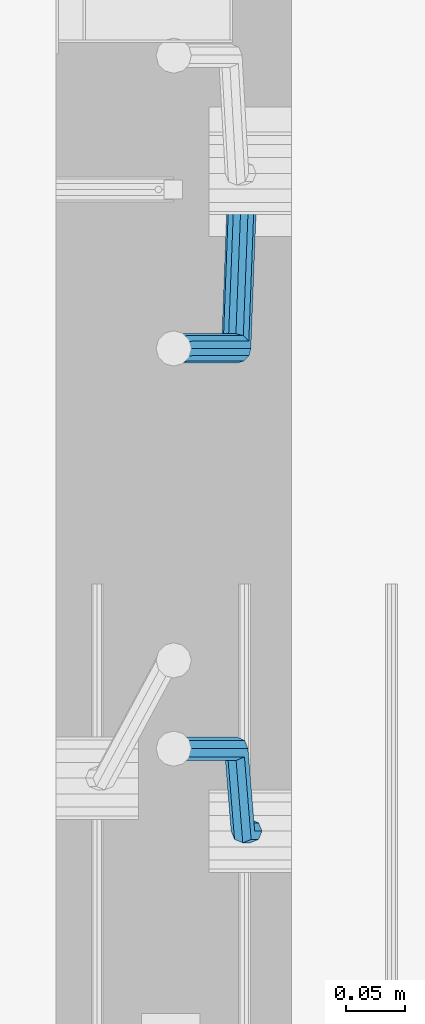
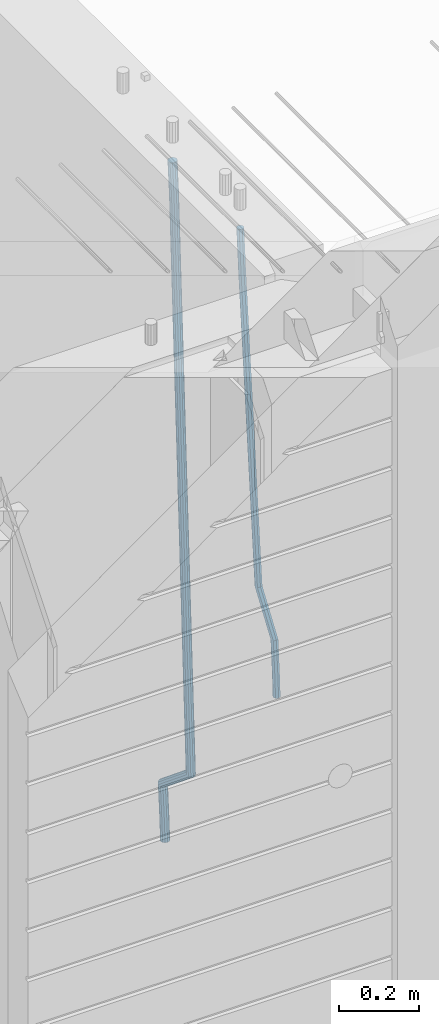
# One storey, part 109 of 349: 2 beams, 1 element without a shape of its own.
"""IFC2X3 building model written with IfcOpenShell, lengths in millimetres."""

from ifc_helpers import new_model, si_unit, frame, origin_with_axes, place, context, subcontext, project, spatial, faceted_brep, material, type_object, element, aggregate, save


model = new_model("IFC2X3")

# Units and contexts
model_context = context("Model", 3, precision=1e-05, world=origin_with_axes())
body_context = subcontext(model_context, "Body", "Model", "MODEL_VIEW")
ifc_project = project(units=[si_unit("LENGTHUNIT", "METRE", prefix="MILLI"), si_unit("AREAUNIT", "SQUARE_METRE"), si_unit("VOLUMEUNIT", "CUBIC_METRE"), si_unit("MASSUNIT", "GRAM", prefix="KILO"), si_unit("TIMEUNIT", "SECOND"), si_unit("PLANEANGLEUNIT", "RADIAN"), si_unit("SOLIDANGLEUNIT", "STERADIAN"), si_unit("THERMODYNAMICTEMPERATUREUNIT", "DEGREE_CELSIUS"), si_unit("LUMINOUSINTENSITYUNIT", "LUMEN")], contexts=[model_context])

# Site, building, storey
site_placement = place(None, origin_with_axes())
site = spatial("IfcSite", under=ifc_project, at=site_placement, CompositionType="ELEMENT")
building_placement = place(site_placement, origin_with_axes())
building = spatial("IfcBuilding", under=site, at=building_placement, CompositionType="ELEMENT")
storey_placement = place(building_placement, origin_with_axes())
storey = spatial("IfcBuildingStorey", under=building, at=storey_placement, Name="4", CompositionType="ELEMENT", Elevation=0.0)

# Assembly, beams
assembly_placement = place(storey_placement, origin_with_axes())
assembly = element("IfcElementAssembly", 1, at=assembly_placement, inside=storey, AssemblyPlace="NOTDEFINED", PredefinedType="REINFORCEMENT_UNIT")
ifc_material = material()
beam_type_1 = type_object("IfcBeamType", Name="D20", PredefinedType="NOTDEFINED")
beam_1_placement = place(assembly_placement, frame((28675.0000022791, 8255.00000000393, 91990.0), z_axis=(-0.999642804636942, -0.000205726999925762, -0.0267249099902983), x_axis=(-0.0267249099948371, 4.30000201934385e-08, 0.999642825806181)))
beam_1 = element("IfcBeam", 2, at=beam_1_placement, type_object=beam_type_1, material=ifc_material, Name="JM20", ObjectType="D20", context=body_context, shape_type="Brep", body=[
    faceted_brep([(0.0, -10.0, 0.0), (-4.19531716033816e-08, -7.07106781186667, -7.07106781187031), (60.4266690400545, -7.0710677960451, -7.07106780570757), (60.4266690441291, -9.99999998418934, 6.15546014159918e-09), (0.0, 0.0, -10.0), (60.426669036824, 1.58106558956206e-08, -9.99999999384454), (4.196772351861e-08, 7.07106781186303, -7.07106781186667), (60.4266690363438, 7.07106782768096, -7.07106780570757), (0.0, 10.0, 0.0), (60.4266690388904, 10.0000000158179, 6.15182216279209e-09), (4.196772351861e-08, 7.07106781185939, 7.07106781185939), (60.4266690429649, 7.07106782768096, 7.07106781802577), (0.0, 0.0, 10.0), (60.4266690461809, 1.58179318532348e-08, 10.0000000061555), (-4.19531716033816e-08, -7.07106781187031, 7.07106781185939), (60.4266690466611, -7.07106779605238, 7.07106781802213), (61.0378400410118, -7.07106779588503, -7.07106780564936), (60.991799419251, -9.99999998403655, 6.21366780251265e-09), (61.0569027789461, 1.5985278878361e-08, -9.99999999378269), (61.0378209396877, 7.07106782784831, -7.07106780564936), (60.9917724058905, 10.0000000159635, 6.21366780251265e-09), (60.9457317841297, 7.07106782781193, 7.0710678180767), (60.9266690461809, 1.59488990902901e-08, 10.0000000062028), (60.9457508854539, -7.07106779591413, 7.0710678180767), (61.6489592143771, -7.07106614513759, -7.06310863441468), (61.5568818710308, -9.9999984576425, 0.00735959856683621), (61.6870830769039, 1.71821739058942e-06, -9.99179257185824), (61.6489210170112, 7.07106947854481, -7.06310888312146), (61.556827851804, 10.0000015422847, 0.00735924683976918), (61.4647505084577, 7.07106922979438, 7.07782747982128), (61.4266266459163, 1.36643211590126e-06, 10.0065114172685), (61.464788705809, -7.07106639389531, 7.07782772852806), (173.929884088837, -7.07076285404219, -5.60077011527756), (173.837806745476, -9.99969516654164, 1.46969811770396), (173.968007951422, 0.000305009316434735, -8.52945405272476), (173.929845891558, 7.07137276964022, -5.6007703639807), (173.837752726366, 10.0003048333874, 1.46969776598417), (173.745675383005, 7.07137252088796, 8.54016599896204), (173.70755152042, 0.000304657529341057, 11.4688499364056), (173.745713580298, -7.07076310279444, 8.54016624766882), (178.967651291154, -7.07074924610424, -5.53515860522748), (179.629472357934, -9.99967952218321, 1.54512834527122), (177.143594814726, 0.000313587164782803, -8.48809544264077), (175.225810474018, 7.07137627027805, -5.58389181644088), (174.337710326101, 10.0003061838652, 1.47620917704262), (174.999531392881, 7.07137590778439, 8.5564961275486), (176.823587869323, 0.000313074517180212, 11.5094329649655), (178.741372210017, -7.07074960859609, 8.60522933875836), (183.345669120055, -4.57893716864601, -5.45009559540631), (184.66265755528, -7.13496947462954, 1.64292097623184), (179.903304691441, 1.57104232098936, -8.43447546265816), (176.352054665098, 7.71239441757098, -5.56200937456015), (174.772193143071, 10.2475983542226, 1.48465099193709), (176.089181578311, 7.69156604824093, 8.57766756357887), (179.531546006911, 1.54158655860192, 11.5620474308307), (183.082796033268, -4.59976553797787, 8.68958134273271), (300.866238429953, 62.309592161384, -3.16672130776351), (302.183226865163, 59.7535598554005, 3.92629526388191), (297.423874001339, 68.4595716510194, -6.15110117501899), (293.872623974981, 74.6009237475992, -3.27863508691371), (292.292762452984, 77.1361276842526, 3.7680252795908), (293.609750888194, 74.5800953782691, 10.8610418512253), (297.052115316808, 68.4301158886319, 13.8454217184808), (300.603365343151, 62.2887637920539, 10.9729556303828), (301.984297885341, 62.9459518481417, -3.14499789178808), (302.617709682163, 60.0008520257597, 3.93473707877274), (300.171977137725, 70.023694240961, -6.09770670902071), (298.242380353928, 77.0880337014878, -3.19373259352506), (297.325839159952, 80.0007759829532, 3.86581580262282), (297.959250956774, 77.0556761605694, 10.9455507731909), (299.771571704376, 69.9779337677501, 13.8982595904236), (301.701168488187, 62.9135943072251, 10.9942854749243), (303.270651347979, 62.9459576083173, -3.11711828318948), (303.117592289826, 60.0008542641881, 3.94557121718026), (303.333733847743, 70.0237083990232, -6.02918080060772), (303.269886916285, 77.0880562142083, -3.08476960685584), (303.116511220142, 80.0008019130601, 3.99131915397084), (302.963452161959, 77.0556985689309, 11.0540086543406), (302.900369662209, 69.9779477782249, 13.9660711717588), (302.964216593668, 62.9135999630416, 11.0216599780069), (1294.7217320068, 62.9503972368293, 18.3709632433638), (1294.56867294862, 60.005293892702, 25.4336527437299), (1294.78481450655, 70.0281480275353, 15.4589007259456), (1294.72096757509, 77.0924958427204, 18.4033119196974), (1294.56759187893, 80.0052415415721, 25.4794006805241), (1294.41453282078, 77.0601381974448, 32.5420901808939), (1294.35145032103, 69.9823874067388, 35.4541526983121), (1294.41529725248, 62.9180395915519, 32.5097415045602), (1295.22161461448, 62.9503994752577, 18.3817973817677), (1295.07888017438, 60.0052961773617, 25.4447106513508), (1295.31867057628, 70.028150418093, 15.4704711836021), (1295.31319399366, 77.0924984946578, 18.4161474592547), (1295.20839297447, 80.0052444110206, 25.4932889968004), (1295.06565853437, 77.0601411131283, 32.5562022663908), (1294.96860257258, 69.9823901702894, 35.4675284645564), (1294.97407915516, 62.9180420937282, 32.5218521889037), (1295.72152784184, 62.94388042639, 18.3884507330331), (1295.58911865226, 59.9986424835042, 25.4515014215031), (1295.85255934671, 70.0211883158863, 15.477576715788), (1295.90545668837, 77.0847751754136, 18.4240298907134), (1295.84923332153, 79.9968876216644, 25.5018179488325), (1295.71682413192, 77.0516496787768, 32.5648686373061), (1295.58579262707, 69.9743417892805, 35.4757426545511), (1295.53289528542, 62.9107549297532, 32.5292894796257), (1317.55234549895, 62.6591986870044, 18.6789973526284), (1317.41993630935, 59.7139607441186, 25.742048041102), (1317.68337700378, 69.7365065765007, 15.7681233353796), (1317.73627434546, 76.8000934360261, 18.7145765103051), (1317.68005097858, 79.7122058822752, 25.7923645684241), (1317.54764178899, 76.7669679393894, 32.8554152568977), (1317.41661028414, 69.6896600498949, 35.7662892741391), (1317.36371294248, 62.6260731903676, 32.8198360992174), (1318.18764454535, 62.6509141582064, 18.6874525554158), (1318.08001896468, 59.7053530281173, 25.7508330892488), (1318.26149780396, 69.7289676726632, 15.7758175521922), (1318.25831650323, 76.7932858179247, 18.7215243757819), (1318.17996420598, 79.7056868334112, 25.7990179196931), (1318.07233862529, 76.7601257033202, 32.8623984535188), (1317.9984853667, 69.6820721888635, 35.7740334567425), (1318.00166666745, 62.617754043602, 32.82832663316), (1318.82299738188, 62.6527874709518, 18.695714940186), (1318.74015733854, 59.7073214972279, 25.7594258266035), (1318.83966783619, 69.7306617061313, 15.783316930032), (1318.78040337538, 76.7948214685675, 18.7282750514532), (1318.67992031686, 79.7071777761994, 25.8054727775416), (1318.59708027351, 76.7617118024755, 32.8691836639591), (1318.58040981922, 69.683837567296, 35.7815816741204), (1318.63967428004, 62.6196778048579, 32.8366235526955), (1418.84378630333, 62.9510503382135, 19.9930854252816), (1418.76094625996, 60.0055843644896, 27.0567963116991), (1418.86045675761, 70.0289245733893, 17.080687415124), (1418.8011922968, 77.0930843358292, 20.0256455365488), (1418.70070923828, 80.0054406434592, 27.1028432626408), (1418.61786919495, 77.0599746697353, 34.1665541490511), (1418.60119874065, 69.9821004345595, 37.078952159216), (1418.66046320145, 62.9179406721196, 34.1339940377911)], [[[0, 1, 2, 3]], [[1, 4, 5, 2]], [[4, 6, 7, 5]], [[6, 8, 9, 7]], [[8, 10, 11, 9]], [[10, 12, 13, 11]], [[12, 14, 15, 13]], [[14, 0, 3, 15]], [[14, 12, 10, 8, 6, 4, 1, 0]], [[3, 2, 16, 17]], [[2, 5, 18, 16]], [[5, 7, 19, 18]], [[7, 9, 20, 19]], [[9, 11, 21, 20]], [[11, 13, 22, 21]], [[13, 15, 23, 22]], [[15, 3, 17, 23]], [[17, 16, 24, 25]], [[16, 18, 26, 24]], [[18, 19, 27, 26]], [[19, 20, 28, 27]], [[20, 21, 29, 28]], [[21, 22, 30, 29]], [[22, 23, 31, 30]], [[23, 17, 25, 31]], [[25, 24, 32, 33]], [[24, 26, 34, 32]], [[26, 27, 35, 34]], [[27, 28, 36, 35]], [[28, 29, 37, 36]], [[29, 30, 38, 37]], [[30, 31, 39, 38]], [[31, 25, 33, 39]], [[33, 32, 40, 41]], [[32, 34, 42, 40]], [[34, 35, 43, 42]], [[35, 36, 44, 43]], [[36, 37, 45, 44]], [[37, 38, 46, 45]], [[38, 39, 47, 46]], [[39, 33, 41, 47]], [[41, 40, 48, 49]], [[40, 42, 50, 48]], [[42, 43, 51, 50]], [[43, 44, 52, 51]], [[44, 45, 53, 52]], [[45, 46, 54, 53]], [[46, 47, 55, 54]], [[47, 41, 49, 55]], [[49, 48, 56, 57]], [[48, 50, 58, 56]], [[50, 51, 59, 58]], [[51, 52, 60, 59]], [[52, 53, 61, 60]], [[53, 54, 62, 61]], [[54, 55, 63, 62]], [[55, 49, 57, 63]], [[57, 56, 64, 65]], [[56, 58, 66, 64]], [[58, 59, 67, 66]], [[59, 60, 68, 67]], [[60, 61, 69, 68]], [[61, 62, 70, 69]], [[62, 63, 71, 70]], [[63, 57, 65, 71]], [[65, 64, 72, 73]], [[64, 66, 74, 72]], [[66, 67, 75, 74]], [[67, 68, 76, 75]], [[68, 69, 77, 76]], [[69, 70, 78, 77]], [[70, 71, 79, 78]], [[71, 65, 73, 79]], [[73, 72, 80, 81]], [[72, 74, 82, 80]], [[74, 75, 83, 82]], [[75, 76, 84, 83]], [[76, 77, 85, 84]], [[77, 78, 86, 85]], [[78, 79, 87, 86]], [[79, 73, 81, 87]], [[81, 80, 88, 89]], [[80, 82, 90, 88]], [[82, 83, 91, 90]], [[83, 84, 92, 91]], [[84, 85, 93, 92]], [[85, 86, 94, 93]], [[86, 87, 95, 94]], [[87, 81, 89, 95]], [[89, 88, 96, 97]], [[88, 90, 98, 96]], [[90, 91, 99, 98]], [[91, 92, 100, 99]], [[92, 93, 101, 100]], [[93, 94, 102, 101]], [[94, 95, 103, 102]], [[95, 89, 97, 103]], [[97, 96, 104, 105]], [[96, 98, 106, 104]], [[98, 99, 107, 106]], [[99, 100, 108, 107]], [[100, 101, 109, 108]], [[101, 102, 110, 109]], [[102, 103, 111, 110]], [[103, 97, 105, 111]], [[105, 104, 112, 113]], [[104, 106, 114, 112]], [[106, 107, 115, 114]], [[107, 108, 116, 115]], [[108, 109, 117, 116]], [[109, 110, 118, 117]], [[110, 111, 119, 118]], [[111, 105, 113, 119]], [[113, 112, 120, 121]], [[112, 114, 122, 120]], [[114, 115, 123, 122]], [[115, 116, 124, 123]], [[116, 117, 125, 124]], [[117, 118, 126, 125]], [[118, 119, 127, 126]], [[119, 113, 121, 127]], [[121, 120, 128, 129]], [[120, 122, 130, 128]], [[122, 123, 131, 130]], [[123, 124, 132, 131]], [[124, 125, 133, 132]], [[125, 126, 134, 133]], [[126, 127, 135, 134]], [[127, 121, 129, 135]], [[130, 131, 132, 133, 134, 135, 129, 128]]]),
])
beam_type_2 = type_object("IfcBeamType", Name="D25", PredefinedType="NOTDEFINED")
beam_2_placement = place(assembly_placement, frame((28675.0000022791, 8815.00000000393, 91210.0), z_axis=(-0.999642804636942, -0.000205726999925762, -0.0267249099902983), x_axis=(-0.0267249099948371, 4.30000201934385e-08, 0.999642825806181)))
beam_2 = element("IfcBeam", 3, at=beam_2_placement, type_object=beam_type_2, material=ifc_material, Name="JM25", ObjectType="D25", context=body_context, shape_type="Brep", body=[
    faceted_brep([(-7.41420080885291e-08, -12.5, -3.63797880709171e-12), (-6.42030499875546e-08, -10.8253175473074, -6.25000000000364), (60.4103898235917, -10.8253175318459, -6.2499999938409), (60.4103898269532, -12.4999999845422, 6.16273609921336e-09), (-3.70782800018787e-08, -6.25000000000364, -10.8253175473074), (60.4103898202884, -6.24999998454587, -10.8253175411446), (-1.45519152283669e-11, -3.63797880709171e-12, -12.5), (60.4103898179019, 1.54577719513327e-08, -12.4999999938373), (3.70637280866504e-08, 6.25, -10.8253175473074), (60.410389817087, 6.25000001545777, -10.825317541141), (6.42030499875546e-08, 10.8253175473001, -6.25000000000364), (60.410389818062, 10.8253175627578, -6.24999999383726), (7.41420080885291e-08, 12.4999999999927, 0.0), (60.4103898205503, 12.5000000154541, 6.16273609921336e-09), (6.42176019027829e-08, 10.8253175473001, 6.24999999999636), (60.4103898238973, 10.8253175627651, 6.2500000061591), (3.70928319171071e-08, 6.24999999999636, 10.8253175473037), (60.4103898272151, 6.25000001546141, 10.8253175534664), (1.45519152283669e-11, -3.63797880709171e-12, 12.4999999999964), (60.4103898296162, 1.54541339725256e-08, 12.5000000061591), (-3.7049176171422e-08, -6.25000000000364, 10.8253175473001), (60.4103898304165, -6.24999998454587, 10.8253175534701), (-6.41884980723262e-08, -10.8253175473074, 6.25), (60.4103898294561, -10.8253175318459, 6.25000000616637), (61.0324985728803, -10.8253175316895, -6.24999999377542), (60.991802792938, -12.4999999843931, 6.22458173893392e-09), (61.0622854283865, -6.24999998437852, -10.8253175410755), (61.0731819955545, 1.5628756955266e-08, -12.4999999937718), (61.0622685480339, 6.25000001562512, -10.8253175410791), (61.032469335245, 10.8253175629216, -6.24999999377178), (60.9917690322181, 12.5000000156033, 6.22458173893392e-09), (60.9510732522613, 10.8253175629034, 6.25000000621731), (60.9212863967696, 6.25000001558874, 10.8253175535247), (60.9103898296162, 1.55814632307738e-08, 12.5000000062137), (60.9213032771368, -6.24999998441126, 10.8253175535174), (60.9511024898966, -10.8253175317113, 6.25000000621731), (61.6545545670233, -10.8253158516927, -6.24189838219536), (61.573166454793, -12.499998414296, 0.00757164385504439), (61.7141257553885, -6.24999822394238, -10.8168280205282), (61.7359179680789, 1.80548886419274e-06, -12.491368569139), (61.7140919992817, 6.25000177601396, -10.8168282403167), (61.6544960997562, 10.8253192428383, -6.2418987628771), (61.5730989426083, 12.5000015856094, 0.0075712042817031), (61.4917108303925, 10.8253190230062, 6.25704123032847), (61.4321396420273, 6.25000139525582, 10.8319708686649), (61.4103474293224, 1.36582457344048e-06, 12.5065114172721), (61.4321733981196, -6.24999860470052, 10.8319710884571), (61.4917692976451, -10.8253160715249, 6.25704161101385), (170.650707434237, -10.8250214850323, -4.82234049238832), (170.569319321992, -12.4997040476355, 1.42712953365844), (170.710278622631, -6.24970385728193, -9.39727013072479), (170.732070835351, 0.000296172149319318, -11.071810679332), (170.710244866626, 6.2502961426726, -9.39727035051328), (170.650648967101, 10.8256136094988, -4.8223408730737), (170.569251809982, 12.5002959522735, 1.42712909408874), (170.487863697752, 10.8256133896703, 7.67659912013187), (170.428292509343, 6.2502957619181, 12.2515287584683), (170.406500296609, 0.000295732492304523, 13.9260693070792), (170.428326265363, -6.24970423803461, 12.2515289782568), (170.487922164859, -10.825021704859, 7.67659950081725), (171.95945989441, -10.8250179504703, -4.80529539646886), (171.069276921742, -12.4997026973942, 1.43364094472054), (174.195854831123, -6.24969444374983, -9.35187424218384), (177.179221514642, 0.00031358403248305, -10.9878434623934), (180.110169251391, 6.25032152914355, -9.2748464256947), (182.203352962257, 10.8256448100037, -4.67187930471846), (182.897905762278, 12.5003292483925, 1.58769657769517), (182.007722789611, 10.8256445014722, 7.82663291887729), (179.771327852883, 6.25032099474811, 12.3732117645959), (176.787961169364, 0.000312966967612738, 14.0091809848018), (173.857013432615, -6.24969497814527, 12.2961839481068), (171.763829721749, -10.8250182590036, 7.69321682713053), (172.789272050257, -11.8370779460765, -4.78886711087034), (171.386274143355, -12.8863205656235, 1.43991672756601), (176.405878190024, -8.94509510172611, -9.30812109317048), (181.267025868161, -4.98527650023061, -10.9069147643713), (186.070174490029, -1.01865233804529, -9.15685265142747), (189.528324261279, 1.89192364390146, -4.52686248419923), (190.714866743365, 2.96656496173455, 1.74245361104113), (189.311868836463, 1.91732234219126, 7.97123744947385), (185.695262696681, -0.974660502160987, 12.4904914317667), (180.834115018544, -4.93447910365467, 14.0892851029712), (176.030966396691, -8.90110326583999, 12.339222990031), (172.572816625441, -11.8116792477867, 7.70923282279909), (287.643682825365, -151.916436441259, -2.51502591843382), (286.240684918463, -152.965679060806, 3.71375791999526), (291.260288965132, -149.024453596909, -7.03427990073396), (296.121436643283, -145.064634995419, -8.63307357193844), (300.924585265137, -141.098010833231, -6.88301145899459), (304.382735036386, -138.187434851283, -2.25302129176634), (305.569277518473, -137.11279353345, 4.01629480347401), (304.166279611571, -138.162036152991, 10.2450786419104), (300.549673471804, -141.054018997345, 14.7643326242032), (295.688525793681, -145.013837598837, 16.3631262954077), (290.885377171784, -148.980461761024, 14.6130641824639), (287.427227400578, -151.891037742971, 9.98307401523562), (294.916872503818, -160.787003426849, -2.37103424950692), (294.057255182415, -162.498966818901, 3.86850721808514), (297.130944177028, -156.184453900582, -6.91805504216973), (300.10621148521, -149.924567668779, -8.55418461054069), (303.04545395587, -143.684676191968, -6.84102335805801), (305.16110394265, -139.136753352217, -2.23761145882963), (305.886274740114, -137.499411401677, 4.02257058631221), (305.026657418683, -139.211374793726, 10.2621120539116), (302.812585745487, -143.813924319997, 14.8091328465744), (299.83731843729, -150.073810551799, 16.445262414938), (296.89807596663, -156.313702028609, 14.732101162459), (294.782425979865, -160.861624868359, 10.1286892632306), (306.388880108789, -160.787002563869, -2.36635924463553), (306.386337397649, -162.498965891449, 3.87353149295086), (306.390733102453, -156.184453204016, -6.91428154760433), (306.391399870467, -149.924567195976, -8.55162330764142), (306.390701752913, -143.684675940322, -6.83966012240489), (306.388825809801, -139.13675325986, -2.23711114485923), (306.386274698583, -137.499411364064, 4.02277434335338), (306.383731987473, -139.21137469164, 10.2626650809325), (306.381878993809, -143.813924051496, 14.8105873839049), (306.38121222578, -150.073810059535, 16.4479291439384), (306.381910343349, -156.31370131519, 14.7359659587019), (306.38378628646, -160.86162399565, 10.1334169811526), (2074.25685482159, -160.78686957629, -1.64592811491093), (2074.25431211045, -162.49883290387, 4.59396262267182), (2074.25870781526, -156.184320216433, -6.19385041787609), (2074.25937458327, -149.924434208398, -7.83119217791682), (2074.25867646572, -143.684542952742, -6.11922899268029), (2074.25680052261, -139.136620272282, -1.51668001513099), (2074.25424941139, -137.499278376485, 4.7432054730707), (2074.25170670026, -139.211241704063, 10.9830962106571), (2074.24985370661, -143.813791063918, 15.5310185136332), (2074.24918693858, -150.073677071958, 17.1683602736666), (2074.24988505615, -156.313568327612, 15.4563970884265), (2074.25176099925, -160.861491008072, 10.8538481108772), (2074.83800415983, -160.786869532572, -1.64569128836229), (2074.78405199363, -162.498832864021, 4.59417849914462), (2074.89919820712, -156.184320168253, -6.19358940901657), (2074.95123723999, -149.924434156354, -7.83091023412271), (2074.98017744161, -143.684542898467, -6.11893497085839), (2074.9782643083, -139.136620218011, -1.51638600846127), (2074.94601046259, -137.499278324447, 4.74348737546097), (2074.89205829642, -139.211241655892, 10.9833571629642), (2074.83086424912, -143.813791020213, 15.5312552836185), (2074.77882521624, -150.073677032115, 17.1685761087319), (2074.74988501464, -156.313568289999, 15.4566008454603), (2074.75179814795, -160.861490970456, 10.8540518830705), (2075.41905269311, -160.794446422529, -1.63795810662486), (2075.31369998924, -162.505739489452, 4.60122759051956), (2075.53957750089, -156.192670733069, -6.18506659349441), (2075.64297988769, -149.933454500813, -7.82170382312688), (2075.70155326747, -143.693949660443, -6.10933417154229), (2075.69960295041, -139.146026495109, -1.50678570403034), (2075.6376515224, -137.508297344199, 4.75269243442381), (2075.53229881854, -139.219590411121, 10.9918781315719), (2075.41177401076, -143.821366100581, 15.5389866184414), (2075.30837162396, -150.080582332837, 17.1756238480739), (2075.24979824419, -156.320087173208, 15.4632541964893), (2075.25174856123, -160.868010338543, 10.8607057289737), (2097.19475506655, -161.07840222163, -1.34814502872177), (2097.0894023627, -162.789695288553, 4.89104066842629), (2097.31527987434, -156.47662653217, -5.89525351558768), (2097.41868226114, -150.217410299914, -7.53189074522379), (2097.47725564092, -143.977905459546, -5.8195210936392), (2097.47530532385, -139.42998229421, -1.21697262612361), (2097.41335389586, -137.7922531433, 5.0425055123269), (2097.308001192, -139.503546210224, 11.2816912094786), (2097.18747638421, -144.105321899684, 15.8287996963445), (2097.08407399742, -150.36453813194, 17.465436925977), (2097.02550061764, -156.604042972309, 15.7530672743924), (2097.02745093469, -161.151966137644, 11.1505188068804), (2097.88009758113, -161.08733910817, -1.33902379716892), (2097.78950535266, -162.798824652125, 4.90035834732043), (2097.96299662867, -156.48507277769, -5.88663304572037), (2098.01598976244, -150.225199207291, -7.52394117269068), (2098.02487751505, -143.985046464883, -5.81223278769903), (2097.98727842035, -139.436658438441, -1.21015877018363), (2097.9132671254, -137.79877202651, 5.04915886335584), (2097.82267489695, -139.510257570466, 11.2885410078416), (2097.73977584939, -144.112523900945, 15.8361502563967), (2097.68678271561, -150.372397471347, 17.4734583833706), (2097.67789496301, -156.612550213753, 15.7617499983789), (2097.7154940577, -161.160938240195, 11.1596759808635), (2098.56549792843, -161.085317088931, -1.33009606953055), (2098.4896672887, -162.796737016384, 4.9094834726202), (2098.61076827119, -156.483178710125, -5.87820933279363), (2098.61334816522, -150.223461142012, -7.51619304119231), (2098.57254632999, -143.98345065182, -5.80515078284952), (2098.49929558429, -139.435153011162, -1.20355494909745), (2098.4132234063, -137.797280899784, 5.05560057250841), (2098.33739276657, -139.508700827235, 11.2951801146628), (2098.29212242381, -144.110839206043, 15.8432933779259), (2098.28954252979, -150.370556774154, 17.4812770863246), (2098.33034436501, -156.610567264344, 15.7702348279781), (2098.40359511071, -161.158864905006, 11.1686389942297), (2198.56627518767, -160.787113942532, -0.0329775665668421), (2198.49044454792, -162.498533869981, 6.20660197558027), (2198.61154553041, -156.184975563721, -4.58109082982992), (2198.61412542444, -149.92525799561, -6.21907453823587), (2198.57332358921, -143.68524750542, -4.50803227988581), (2198.50007284353, -139.136949864758, 0.0935635538662609), (2198.41400066552, -137.499077753379, 6.35271907547576), (2198.33817002579, -139.210497680831, 12.5922986176229), (2198.29289968305, -143.81263605964, 17.1404118808859), (2198.29031978901, -150.072353627755, 18.7783955892846), (2198.33112162424, -156.312364117945, 17.0673533309418), (2198.40437236994, -160.860661758603, 12.4657574971934)], [[[0, 1, 2, 3]], [[1, 4, 5, 2]], [[4, 6, 7, 5]], [[6, 8, 9, 7]], [[8, 10, 11, 9]], [[10, 12, 13, 11]], [[12, 14, 15, 13]], [[14, 16, 17, 15]], [[16, 18, 19, 17]], [[18, 20, 21, 19]], [[20, 22, 23, 21]], [[22, 0, 3, 23]], [[22, 20, 18, 16, 14, 12, 10, 8, 6, 4, 1, 0]], [[3, 2, 24, 25]], [[2, 5, 26, 24]], [[5, 7, 27, 26]], [[7, 9, 28, 27]], [[9, 11, 29, 28]], [[11, 13, 30, 29]], [[13, 15, 31, 30]], [[15, 17, 32, 31]], [[17, 19, 33, 32]], [[19, 21, 34, 33]], [[21, 23, 35, 34]], [[23, 3, 25, 35]], [[25, 24, 36, 37]], [[24, 26, 38, 36]], [[26, 27, 39, 38]], [[27, 28, 40, 39]], [[28, 29, 41, 40]], [[29, 30, 42, 41]], [[30, 31, 43, 42]], [[31, 32, 44, 43]], [[32, 33, 45, 44]], [[33, 34, 46, 45]], [[34, 35, 47, 46]], [[35, 25, 37, 47]], [[37, 36, 48, 49]], [[36, 38, 50, 48]], [[38, 39, 51, 50]], [[39, 40, 52, 51]], [[40, 41, 53, 52]], [[41, 42, 54, 53]], [[42, 43, 55, 54]], [[43, 44, 56, 55]], [[44, 45, 57, 56]], [[45, 46, 58, 57]], [[46, 47, 59, 58]], [[47, 37, 49, 59]], [[49, 48, 60, 61]], [[48, 50, 62, 60]], [[50, 51, 63, 62]], [[51, 52, 64, 63]], [[52, 53, 65, 64]], [[53, 54, 66, 65]], [[54, 55, 67, 66]], [[55, 56, 68, 67]], [[56, 57, 69, 68]], [[57, 58, 70, 69]], [[58, 59, 71, 70]], [[59, 49, 61, 71]], [[61, 60, 72, 73]], [[60, 62, 74, 72]], [[62, 63, 75, 74]], [[63, 64, 76, 75]], [[64, 65, 77, 76]], [[65, 66, 78, 77]], [[66, 67, 79, 78]], [[67, 68, 80, 79]], [[68, 69, 81, 80]], [[69, 70, 82, 81]], [[70, 71, 83, 82]], [[71, 61, 73, 83]], [[73, 72, 84, 85]], [[72, 74, 86, 84]], [[74, 75, 87, 86]], [[75, 76, 88, 87]], [[76, 77, 89, 88]], [[77, 78, 90, 89]], [[78, 79, 91, 90]], [[79, 80, 92, 91]], [[80, 81, 93, 92]], [[81, 82, 94, 93]], [[82, 83, 95, 94]], [[83, 73, 85, 95]], [[85, 84, 96, 97]], [[84, 86, 98, 96]], [[86, 87, 99, 98]], [[87, 88, 100, 99]], [[88, 89, 101, 100]], [[89, 90, 102, 101]], [[90, 91, 103, 102]], [[91, 92, 104, 103]], [[92, 93, 105, 104]], [[93, 94, 106, 105]], [[94, 95, 107, 106]], [[95, 85, 97, 107]], [[97, 96, 108, 109]], [[96, 98, 110, 108]], [[98, 99, 111, 110]], [[99, 100, 112, 111]], [[100, 101, 113, 112]], [[101, 102, 114, 113]], [[102, 103, 115, 114]], [[103, 104, 116, 115]], [[104, 105, 117, 116]], [[105, 106, 118, 117]], [[106, 107, 119, 118]], [[107, 97, 109, 119]], [[109, 108, 120, 121]], [[108, 110, 122, 120]], [[110, 111, 123, 122]], [[111, 112, 124, 123]], [[112, 113, 125, 124]], [[113, 114, 126, 125]], [[114, 115, 127, 126]], [[115, 116, 128, 127]], [[116, 117, 129, 128]], [[117, 118, 130, 129]], [[118, 119, 131, 130]], [[119, 109, 121, 131]], [[121, 120, 132, 133]], [[120, 122, 134, 132]], [[122, 123, 135, 134]], [[123, 124, 136, 135]], [[124, 125, 137, 136]], [[125, 126, 138, 137]], [[126, 127, 139, 138]], [[127, 128, 140, 139]], [[128, 129, 141, 140]], [[129, 130, 142, 141]], [[130, 131, 143, 142]], [[131, 121, 133, 143]], [[133, 132, 144, 145]], [[132, 134, 146, 144]], [[134, 135, 147, 146]], [[135, 136, 148, 147]], [[136, 137, 149, 148]], [[137, 138, 150, 149]], [[138, 139, 151, 150]], [[139, 140, 152, 151]], [[140, 141, 153, 152]], [[141, 142, 154, 153]], [[142, 143, 155, 154]], [[143, 133, 145, 155]], [[145, 144, 156, 157]], [[144, 146, 158, 156]], [[146, 147, 159, 158]], [[147, 148, 160, 159]], [[148, 149, 161, 160]], [[149, 150, 162, 161]], [[150, 151, 163, 162]], [[151, 152, 164, 163]], [[152, 153, 165, 164]], [[153, 154, 166, 165]], [[154, 155, 167, 166]], [[155, 145, 157, 167]], [[157, 156, 168, 169]], [[156, 158, 170, 168]], [[158, 159, 171, 170]], [[159, 160, 172, 171]], [[160, 161, 173, 172]], [[161, 162, 174, 173]], [[162, 163, 175, 174]], [[163, 164, 176, 175]], [[164, 165, 177, 176]], [[165, 166, 178, 177]], [[166, 167, 179, 178]], [[167, 157, 169, 179]], [[169, 168, 180, 181]], [[168, 170, 182, 180]], [[170, 171, 183, 182]], [[171, 172, 184, 183]], [[172, 173, 185, 184]], [[173, 174, 186, 185]], [[174, 175, 187, 186]], [[175, 176, 188, 187]], [[176, 177, 189, 188]], [[177, 178, 190, 189]], [[178, 179, 191, 190]], [[179, 169, 181, 191]], [[181, 180, 192, 193]], [[180, 182, 194, 192]], [[182, 183, 195, 194]], [[183, 184, 196, 195]], [[184, 185, 197, 196]], [[185, 186, 198, 197]], [[186, 187, 199, 198]], [[187, 188, 200, 199]], [[188, 189, 201, 200]], [[189, 190, 202, 201]], [[190, 191, 203, 202]], [[191, 181, 193, 203]], [[194, 195, 196, 197, 198, 199, 200, 201, 202, 203, 193, 192]]]),
])
aggregate(assembly, [beam_1, beam_2])

save(model, "model.ifc")
